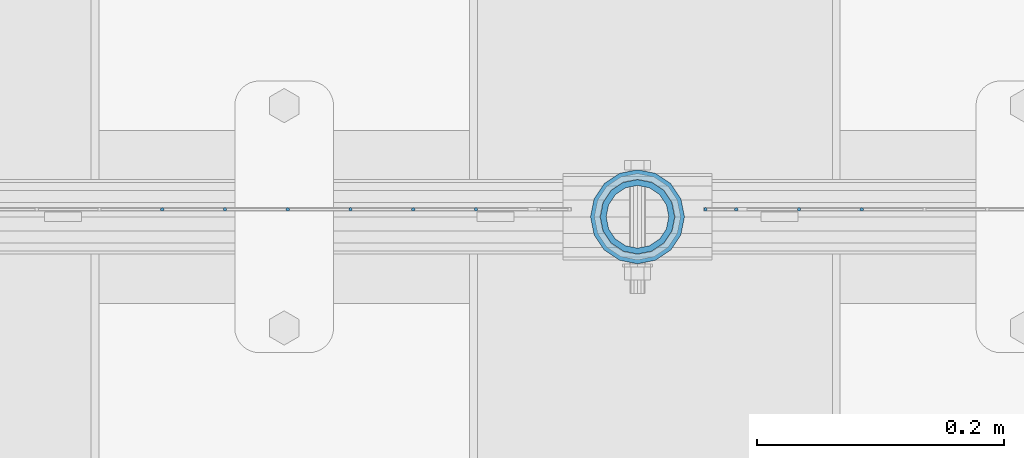
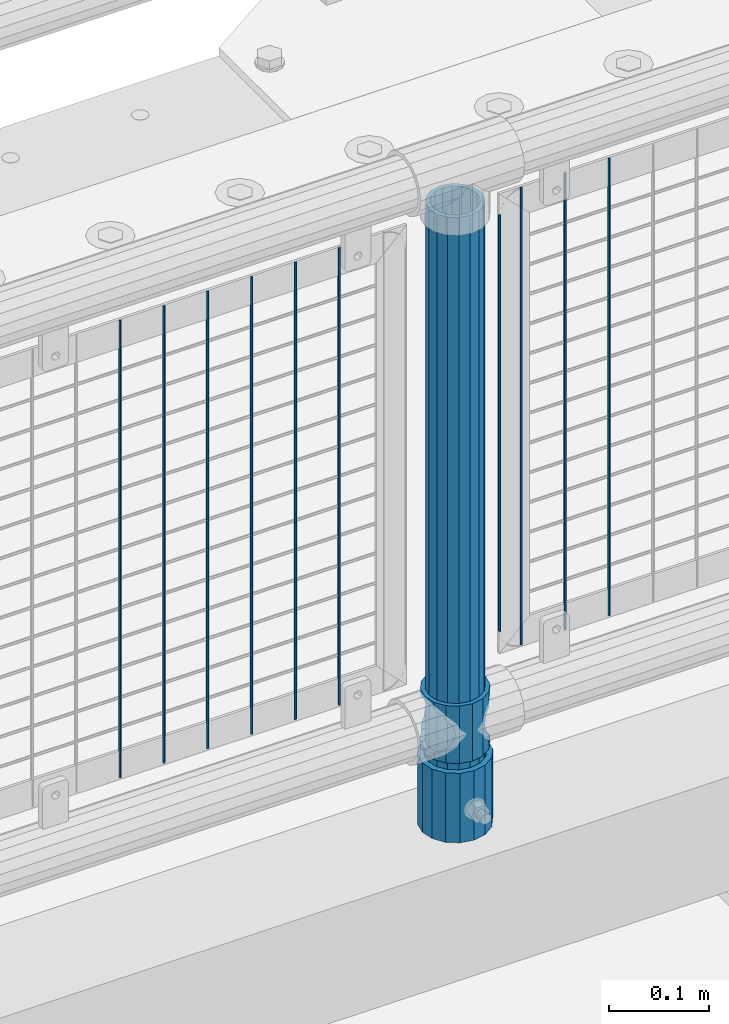
# One storey, part 84 of 270: 13 columns.
"""IFC2X3 building model written with IfcOpenShell, lengths in millimetres."""

from ifc_helpers import new_model, si_unit, frame, origin_with_axes, place, context, subcontext, project, spatial, faceted_brep, material, type_object, element, save


model = new_model("IFC2X3")

# Units and contexts
model_context = context("Model", 3, precision=1e-05, world=origin_with_axes())
body_context = subcontext(model_context, "Body", "Model", "MODEL_VIEW")
ifc_project = project(units=[si_unit("LENGTHUNIT", "METRE", prefix="MILLI"), si_unit("AREAUNIT", "SQUARE_METRE"), si_unit("VOLUMEUNIT", "CUBIC_METRE"), si_unit("MASSUNIT", "GRAM", prefix="KILO"), si_unit("TIMEUNIT", "SECOND"), si_unit("PLANEANGLEUNIT", "RADIAN"), si_unit("SOLIDANGLEUNIT", "STERADIAN"), si_unit("THERMODYNAMICTEMPERATUREUNIT", "DEGREE_CELSIUS"), si_unit("LUMINOUSINTENSITYUNIT", "LUMEN")], contexts=[model_context])

# Site, building, storey
site_placement = place(None, origin_with_axes())
site = spatial("IfcSite", under=ifc_project, at=site_placement, CompositionType="ELEMENT")
building_placement = place(site_placement, origin_with_axes())
building = spatial("IfcBuilding", under=site, at=building_placement, Name="Standard", CompositionType="ELEMENT")
storey_placement = place(building_placement, origin_with_axes())
storey = spatial("IfcBuildingStorey", under=building, at=storey_placement, Name="Undefined", CompositionType="ELEMENT", Elevation=0.0)

# Columns
ifc_material_1 = material()
column_type_1 = type_object("IfcColumnType", PredefinedType="NOTDEFINED")
column_1_placement = place(storey_placement, frame((8786.0, -16335.5, 168.02), z_axis=(-1.0, 0.0, 0.0), x_axis=(0.0, 0.0, 1.0)))
element("IfcColumn", 1, at=column_1_placement, inside=storey, type_object=column_type_1, material=ifc_material_1, context=body_context, shape_type="Brep", body=[
    faceted_brep([(0.0, -25.3500000000004, 0.0), (0.0, -23.4203461491616, 9.70102501045403), (760.0, -23.4203461491616, 9.70102501045403), (760.0, -25.3500000000004, 0.0), (0.0, -17.9251569030785, 17.9251569030785), (760.0, -17.9251569030785, 17.9251569030785), (0.0, -9.70102501045585, 23.4203461491597), (760.0, -9.70102501045585, 23.4203461491597), (0.0, 0.0, 25.3499999999985), (760.0, 0.0, 25.3499999999985), (0.0, 9.70102501045585, 23.4203461491597), (760.0, 9.70102501045585, 23.4203461491597), (0.0, 17.9251569030785, 17.9251569030785), (760.0, 17.9251569030785, 17.9251569030785), (0.0, 23.4203461491616, 9.70102501045403), (760.0, 23.4203461491616, 9.70102501045403), (0.0, 25.3500000000004, 0.0), (760.0, 25.3500000000004, 0.0), (0.0, 23.4203461491616, -9.70102501045403), (760.0, 23.4203461491616, -9.70102501045403), (0.0, 17.9251569030785, -17.9251569030785), (760.0, 17.9251569030785, -17.9251569030785), (0.0, 9.70102501045585, -23.4203461491597), (760.0, 9.70102501045585, -23.4203461491597), (0.0, 0.0, -25.3499999999985), (760.0, 0.0, -25.3499999999985), (0.0, -9.70102501045585, -23.4203461491597), (760.0, -9.70102501045585, -23.4203461491597), (0.0, -17.9251569030785, -17.9251569030785), (760.0, -17.9251569030785, -17.9251569030785), (0.0, -23.4203461491616, -9.70102501045403), (760.0, -23.4203461491616, -9.70102501045403), (0.0, -30.1499999999996, 0.0), (0.0, -27.8549679052157, -11.5379054858058), (760.0, -27.8549679052157, -11.5379054858058), (760.0, -30.1499999999996, 0.0), (0.0, -21.3192694527752, -21.3192694527752), (760.0, -21.3192694527752, -21.3192694527752), (0.0, -11.5379054858076, -27.8549679052157), (760.0, -11.5379054858076, -27.8549679052157), (0.0, 0.0, -30.1500000000015), (760.0, 0.0, -30.1500000000015), (0.0, 11.5379054858076, -27.8549679052157), (760.0, 11.5379054858076, -27.8549679052157), (0.0, 21.3192694527752, -21.3192694527752), (760.0, 21.3192694527752, -21.3192694527752), (0.0, 27.8549679052157, -11.5379054858058), (760.0, 27.8549679052157, -11.5379054858058), (0.0, 30.1499999999996, 0.0), (760.0, 30.1499999999996, 0.0), (0.0, 27.8549679052157, 11.5379054858058), (760.0, 27.8549679052157, 11.5379054858058), (0.0, 21.3192694527752, 21.3192694527752), (760.0, 21.3192694527752, 21.3192694527752), (0.0, 11.5379054858076, 27.8549679052157), (760.0, 11.5379054858076, 27.8549679052157), (0.0, 0.0, 30.1500000000015), (760.0, 0.0, 30.1500000000015), (0.0, -11.5379054858076, 27.8549679052157), (760.0, -11.5379054858076, 27.8549679052157), (0.0, -21.3192694527752, 21.3192694527752), (760.0, -21.3192694527752, 21.3192694527752), (0.0, -27.8549679052157, 11.5379054858058), (760.0, -27.8549679052157, 11.5379054858058)], [[[0, 1, 2, 3]], [[1, 4, 5, 2]], [[4, 6, 7, 5]], [[6, 8, 9, 7]], [[8, 10, 11, 9]], [[10, 12, 13, 11]], [[12, 14, 15, 13]], [[14, 16, 17, 15]], [[16, 18, 19, 17]], [[18, 20, 21, 19]], [[20, 22, 23, 21]], [[22, 24, 25, 23]], [[24, 26, 27, 25]], [[26, 28, 29, 27]], [[28, 30, 31, 29]], [[30, 0, 3, 31]], [[32, 33, 34, 35]], [[33, 36, 37, 34]], [[36, 38, 39, 37]], [[38, 40, 41, 39]], [[40, 42, 43, 41]], [[42, 44, 45, 43]], [[44, 46, 47, 45]], [[46, 48, 49, 47]], [[48, 50, 51, 49]], [[50, 52, 53, 51]], [[52, 54, 55, 53]], [[54, 56, 57, 55]], [[56, 58, 59, 57]], [[58, 60, 61, 59]], [[60, 62, 63, 61]], [[62, 32, 35, 63]], [[37, 39, 41, 43, 45, 47, 49, 51, 53, 55, 57, 59, 61, 63, 35, 34], [5, 7, 9, 11, 13, 15, 17, 19, 21, 23, 25, 27, 29, 31, 3, 2]], [[62, 60, 58, 56, 54, 52, 50, 48, 46, 44, 42, 40, 38, 36, 33, 32], [30, 28, 26, 24, 22, 20, 18, 16, 14, 12, 10, 8, 6, 4, 1, 0]]]),
])
column_type_2 = type_object("IfcColumnType", PredefinedType="NOTDEFINED")
column_2_placement = place(storey_placement, frame((8786.0, -16335.5, 168.02), z_axis=(0.0, 1.0, 0.0), x_axis=(0.0, 0.0, 1.0)))
element("IfcColumn", 2, at=column_2_placement, inside=storey, type_object=column_type_2, material=ifc_material_1, context=body_context, shape_type="Brep", body=[
    faceted_brep([(0.0, -31.75, 0.0), (0.0, -29.3331751572332, 12.1501989775916), (85.0, -29.3331751572332, 12.1501989775916), (85.0, -31.75, 0.0), (0.0, -22.4506403026717, 22.4506403026735), (85.0, -22.4506403026717, 22.4506403026735), (0.0, -12.1501989775934, 29.3331751572332), (85.0, -12.1501989775934, 29.3331751572332), (0.0, 0.0, 31.75), (85.0, 0.0, 31.75), (0.0, 12.1501989775934, 29.3331751572332), (85.0, 12.1501989775934, 29.3331751572332), (0.0, 22.4506403026717, 22.4506403026735), (85.0, 22.4506403026717, 22.4506403026735), (0.0, 29.3331751572332, 12.1501989775916), (85.0, 29.3331751572332, 12.1501989775916), (0.0, 31.75, 0.0), (85.0, 31.75, 0.0), (0.0, 29.3331751572332, -12.1501989775916), (85.0, 29.3331751572332, -12.1501989775916), (0.0, 22.4506403026717, -22.4506403026735), (85.0, 22.4506403026717, -22.4506403026735), (0.0, 12.1501989775934, -29.3331751572332), (85.0, 12.1501989775934, -29.3331751572332), (0.0, 0.0, -31.75), (85.0, 0.0, -31.75), (0.0, -12.1501989775934, -29.3331751572332), (85.0, -12.1501989775934, -29.3331751572332), (0.0, -22.4506403026717, -22.4506403026735), (85.0, -22.4506403026717, -22.4506403026735), (0.0, -29.3331751572332, -12.1501989775916), (85.0, -29.3331751572332, -12.1501989775916), (0.0, -38.0499999999993, 0.0), (0.0, -35.1536162120537, -14.561104601491), (85.0, -35.1536162120537, -14.561104601491), (85.0, -38.0499999999993, 0.0), (0.0, -26.9054130241493, -26.9054130241475), (85.0, -26.9054130241493, -26.9054130241475), (0.0, -14.5611046014928, -35.1536162120537), (85.0, -14.5611046014928, -35.1536162120537), (0.0, 0.0, -38.0499999999993), (85.0, 0.0, -38.0499999999993), (0.0, 14.5611046014928, -35.1536162120537), (85.0, 14.5611046014928, -35.1536162120537), (0.0, 26.9054130241493, -26.9054130241475), (85.0, 26.9054130241493, -26.9054130241475), (0.0, 35.1536162120537, -14.561104601491), (85.0, 35.1536162120537, -14.561104601491), (0.0, 38.0499999999993, 0.0), (85.0, 38.0499999999993, 0.0), (0.0, 35.1536162120537, 14.561104601491), (85.0, 35.1536162120537, 14.561104601491), (0.0, 26.9054130241493, 26.9054130241475), (85.0, 26.9054130241493, 26.9054130241475), (0.0, 14.5611046014928, 35.1536162120537), (85.0, 14.5611046014928, 35.1536162120537), (0.0, 0.0, 38.0499999999993), (85.0, 0.0, 38.0499999999993), (0.0, -14.5611046014928, 35.1536162120537), (85.0, -14.5611046014928, 35.1536162120537), (0.0, -26.9054130241493, 26.9054130241475), (85.0, -26.9054130241493, 26.9054130241475), (0.0, -35.1536162120537, 14.561104601491), (85.0, -35.1536162120537, 14.561104601491)], [[[0, 1, 2, 3]], [[1, 4, 5, 2]], [[4, 6, 7, 5]], [[6, 8, 9, 7]], [[8, 10, 11, 9]], [[10, 12, 13, 11]], [[12, 14, 15, 13]], [[14, 16, 17, 15]], [[16, 18, 19, 17]], [[18, 20, 21, 19]], [[20, 22, 23, 21]], [[22, 24, 25, 23]], [[24, 26, 27, 25]], [[26, 28, 29, 27]], [[28, 30, 31, 29]], [[30, 0, 3, 31]], [[32, 33, 34, 35]], [[33, 36, 37, 34]], [[36, 38, 39, 37]], [[38, 40, 41, 39]], [[40, 42, 43, 41]], [[42, 44, 45, 43]], [[44, 46, 47, 45]], [[46, 48, 49, 47]], [[48, 50, 51, 49]], [[50, 52, 53, 51]], [[52, 54, 55, 53]], [[54, 56, 57, 55]], [[56, 58, 59, 57]], [[58, 60, 61, 59]], [[60, 62, 63, 61]], [[62, 32, 35, 63]], [[37, 39, 41, 43, 45, 47, 49, 51, 53, 55, 57, 59, 61, 63, 35, 34], [5, 7, 9, 11, 13, 15, 17, 19, 21, 23, 25, 27, 29, 31, 3, 2]], [[62, 60, 58, 56, 54, 52, 50, 48, 46, 44, 42, 40, 38, 36, 33, 32], [30, 28, 26, 24, 22, 20, 18, 16, 14, 12, 10, 8, 6, 4, 1, 0]]]),
])
ifc_material_2 = material(Name="Misc_Undefined")
column_type_3 = type_object("IfcColumnType", PredefinedType="NOTDEFINED")
column_3_placement = place(storey_placement, frame((8786.0, -16335.5, 263.02), z_axis=(-1.0, 0.0, 0.0), x_axis=(0.0, 0.0, 1.0)))
element("IfcColumn", 3, at=column_3_placement, inside=storey, type_object=column_type_3, material=ifc_material_2, context=body_context, shape_type="Brep", body=[
    faceted_brep([(63.1897438117183, 11.6144421722802, -32.8397438117208), (63.1897438117183, 11.6144421722802, -28.0397438117179), (56.6106908090125, 21.4606908090118, -21.46069080901), (56.6106908090125, 21.4606908090118, -27.1226768591005), (61.9623795176767, 13.4513226476338, -32.4743655677703), (46.7644421722812, 28.0397438117179, -11.614442172282), (46.7644421722812, 28.0397438117179, -20.0882031229812), (51.5310424080071, 24.8548033587067, -24.8548033587067), (35.1500000000015, 30.35, 0.0), (35.1500000000008, 30.3500000000004, -16.6306603983612), (23.5355578277203, 28.0397438117179, -11.614442172282), (23.5355578277203, 28.0397438117179, -20.0882031229812), (18.7689575919954, 24.8548033587067, -24.8548033587067), (13.689309190989, 21.4606908090118, -21.46069080901), (13.689309190989, 21.4606908090118, -27.1226768591005), (8.33762048232484, 13.4513226476338, -32.4743655677703), (7.11025618828324, 11.6144421722802, -28.0397438117179), (7.11025618828324, 11.6144421722802, -32.8397438117208), (4.80000000000075, 0.0, -30.3499999999985), (4.80000000000075, 0.0, -35.1500000000015), (7.11025618828319, -11.6144421722802, -28.0397438117179), (7.11025618828319, -11.6144421722802, -32.8397438117172), (13.689309190989, -21.4606908090118, -21.46069080901), (13.689309190989, -21.4606908090118, -27.1226768591041), (8.33762048232484, -13.4513226476338, -32.4743655677703), (23.5355578277203, -28.0397438117179, -11.614442172282), (23.5355578277203, -28.0397438117179, -20.0882031229885), (18.7689575919954, -24.8548033587067, -24.8548033587067), (35.1500000000015, -30.35, 0.0), (35.1500000000008, -30.3500000000004, -16.6306603983721), (46.7644421722812, -28.0397438117179, -11.614442172282), (46.7644421722812, -28.0397438117179, -20.0882031229885), (51.5310424080071, -24.8548033587067, -24.8548033587067), (56.6106908090125, -21.4606908090118, -21.46069080901), (56.6106908090125, -21.4606908090118, -27.1226768591041), (61.9623795176767, -13.4513226476338, -32.4743655677703), (63.1897438117183, -11.6144421722802, -28.0397438117179), (63.1897438117183, -11.6144421722802, -32.8397438117172), (65.5000000000008, 0.0, -30.3499999999985), (65.5000000000008, 0.0, -35.1500000000015), (0.0, -28.0397438117179, -11.614442172282), (0.0, -30.3500000000004, 0.0), (0.0, -21.4606908090118, -21.46069080901), (0.0, -11.6144421722802, -28.0397438117179), (0.0, 0.0, -30.3499999999985), (0.0, 11.6144421722802, -28.0397438117179), (0.0, 21.4606908090118, -21.46069080901), (0.0, 28.0397438117179, -11.614442172282), (0.0, 30.3500000000004, 0.0), (0.0, 28.0397438117179, 11.614442172282), (23.5355578277192, 28.0397438117179, 11.614442172282), (0.0, 21.4606908090118, 21.46069080901), (13.6893091909879, 21.4606908090118, 21.46069080901), (0.0, 11.6144421722802, 28.0397438117179), (7.11025618828211, 11.6144421722802, 28.0397438117179), (0.0, 0.0, 30.3499999999985), (4.79999999999961, 0.0, 30.3499999999985), (0.0, -11.6144421722802, 28.0397438117179), (7.11025618828205, -11.6144421722802, 28.0397438117179), (0.0, -21.4606908090118, 21.46069080901), (13.6893091909879, -21.4606908090118, 21.46069080901), (0.0, -28.0397438117179, 11.614442172282), (23.5355578277191, -28.0397438117179, 11.614442172282), (0.0, -32.4743655677721, 13.4513226476338), (0.0, -35.1499999999996, 0.0), (70.2999999999993, -35.1499999999996, 0.0), (70.2999999999993, -32.4743655677721, 13.4513226476338), (0.0, 13.4513226476338, -32.4743655677703), (0.0, 24.8548033587067, -24.8548033587067), (0.0, 0.0, -35.1499999999996), (0.0, -13.4513226476338, -32.4743655677703), (0.0, -24.8548033587067, -24.8548033587067), (0.0, -24.8548033587067, 24.8548033587067), (0.0, -13.4513226476338, 32.4743655677703), (0.0, 0.0, 35.1499999999996), (0.0, 13.4513226476338, 32.4743655677703), (0.0, 24.8548033587067, 24.8548033587067), (0.0, 32.4743655677721, 13.4513226476338), (0.0, 35.1499999999996, 0.0), (0.0, 32.4743655677721, -13.4513226476338), (0.0, -32.4743655677721, -13.4513226476338), (70.2999999999993, 32.4743655677721, 13.4513226476338), (70.2999999999993, 35.1499999999996, 0.0), (70.2999999999993, 32.4743655677721, -13.4513226476338), (70.2999999999993, 24.8548033587067, -24.8548033587067), (70.2999999999993, 13.4513226476338, -32.4743655677703), (70.2999999999993, 0.0, -35.1500000000015), (70.2999999999993, -13.4513226476338, -32.4743655677703), (70.2999999999993, -24.8548033587067, -24.8548033587067), (70.2999999999993, -32.4743655677721, -13.4513226476338), (70.2999999999993, 28.0397438117179, 11.614442172282), (70.2999999999993, 21.4606908090118, 21.46069080901), (56.6106908090114, 21.4606908090118, 21.46069080901), (46.7644421722801, 28.0397438117179, 11.614442172282), (70.2999999999993, 11.6144421722802, 28.0397438117179), (63.1897438117172, 11.6144421722802, 28.0397438117179), (70.2999999999993, 0.0, 30.3499999999985), (65.4999999999997, 0.0, 30.3499999999985), (70.2999999999993, -11.6144421722802, 28.0397438117179), (63.1897438117172, -11.6144421722802, 28.0397438117179), (70.2999999999993, -21.4606908090118, 21.46069080901), (56.6106908090114, -21.4606908090118, 21.46069080901), (70.2999999999993, -28.0397438117179, 11.614442172282), (46.7644421722801, -28.0397438117179, 11.614442172282), (70.2999999999993, -11.6144421722802, -28.0397438117179), (70.2999999999993, 0.0, -30.3499999999985), (70.2999999999993, -21.4606908090118, -21.46069080901), (70.2999999999993, -28.0397438117179, -11.614442172282), (70.2999999999993, -30.3500000000004, 0.0), (70.2999999999993, 24.8548033587067, 24.8548033587067), (70.2999999999993, 13.4513226476338, 32.4743655677703), (70.2999999999993, 0.0, 35.1500000000015), (70.2999999999993, -13.4513226476338, 32.4743655677703), (70.2999999999993, -24.8548033587067, 24.8548033587067), (70.2999999999993, 30.3500000000004, 0.0), (70.2999999999993, 28.0397438117179, -11.614442172282), (70.2999999999993, 21.4606908090118, -21.46069080901), (70.2999999999993, 11.6144421722802, -28.0397438117179), (61.9623795176767, 13.4513226476338, 32.4743655677703), (51.5310424080039, 24.8548033587067, 24.8548033587067), (56.6106908090114, 21.4606908090118, 27.1226768591041), (65.4999999999997, 0.0, 35.1500000000015), (63.1897438117172, 11.6144421722802, 32.8397438117172), (63.1897438117172, -11.6144421722802, 32.8397438117172), (61.9623795176767, -13.4513226476338, 32.4743655677703), (56.6106908090114, -21.4606908090118, 27.1226768591077), (51.5310424080071, -24.8548033587067, 24.8548033587067), (18.7689575919954, -24.8548033587067, 24.8548033587067), (46.7644421722801, -28.0397438117179, 20.0882031229849), (35.1499999999996, -30.3500000000004, 16.6306603983649), (23.5355578277191, -28.0397438117179, 20.0882031229849), (8.33762048232262, -13.4513226476338, 32.4743655677703), (13.6893091909879, -21.4606908090118, 27.1226768591077), (4.79999999999961, 0.0, 35.1500000000015), (7.11025618828205, -11.6144421722802, 32.8397438117172), (7.11025618828211, 11.6144421722802, 32.8397438117172), (8.33762048232262, 13.4513226476338, 32.4743655677703), (13.6893091909879, 21.4606908090118, 27.1226768591041), (18.7689575919954, 24.8548033587067, 24.8548033587067), (23.5355578277192, 28.0397438117179, 20.0882031229885), (35.1499999999996, 30.3500000000004, 16.6306603983685), (46.7644421722801, 28.0397438117179, 20.0882031229885)], [[[0, 1, 2, 3, 4]], [[3, 2, 5, 6, 7]], [[6, 5, 8, 9]], [[9, 8, 10, 11]], [[12, 11, 10, 13, 14]], [[15, 14, 13, 16, 17]], [[17, 16, 18, 19]], [[19, 18, 20, 21]], [[21, 20, 22, 23, 24]], [[23, 22, 25, 26, 27]], [[26, 25, 28, 29]], [[29, 28, 30, 31]], [[32, 31, 30, 33, 34]], [[35, 34, 33, 36, 37]], [[37, 36, 38, 39]], [[39, 38, 1, 0]], [[40, 41, 28, 25]], [[42, 40, 25, 22]], [[43, 42, 22, 20]], [[44, 43, 20, 18]], [[45, 44, 18, 16]], [[46, 45, 16, 13]], [[47, 46, 13, 10]], [[48, 47, 10, 8]], [[49, 48, 8, 50]], [[51, 49, 50, 52]], [[53, 51, 52, 54]], [[55, 53, 54, 56]], [[57, 55, 56, 58]], [[59, 57, 58, 60]], [[61, 59, 60, 62]], [[41, 61, 62, 28]], [[63, 64, 65, 66]], [[67, 68, 12, 14, 15]], [[69, 67, 15, 17, 19]], [[24, 70, 69, 19, 21]], [[27, 71, 70, 24, 23]], [[63, 72, 73, 74, 75, 76, 77, 78, 79, 68, 67, 69, 70, 71, 80, 64], [40, 42, 43, 44, 45, 46, 47, 48, 49, 51, 53, 55, 57, 59, 61, 41]], [[78, 77, 81, 82]], [[79, 78, 82, 83]], [[68, 79, 83, 84, 7, 6, 9, 11, 12]], [[7, 84, 85, 4, 3]], [[4, 85, 86, 39, 0]], [[87, 88, 32, 34, 35]], [[86, 87, 35, 37, 39]], [[29, 31, 32, 88, 89, 80, 71, 27, 26]], [[64, 80, 89, 65]], [[90, 91, 92, 93]], [[91, 94, 95, 92]], [[94, 96, 97, 95]], [[96, 98, 99, 97]], [[98, 100, 101, 99]], [[100, 102, 103, 101]], [[104, 105, 38, 36]], [[106, 104, 36, 33]], [[107, 106, 33, 30]], [[108, 107, 30, 28]], [[102, 108, 28, 103]], [[88, 87, 86, 85, 84, 83, 82, 81, 109, 110, 111, 112, 113, 66, 65, 89], [100, 98, 96, 94, 91, 90, 114, 115, 116, 117, 105, 104, 106, 107, 108, 102]], [[118, 110, 109, 119, 120]], [[121, 111, 110, 118, 122]], [[112, 111, 121, 123, 124]], [[113, 112, 124, 125, 126]], [[127, 72, 63, 66, 113, 126, 128, 129, 130]], [[131, 73, 72, 127, 132]], [[133, 74, 73, 131, 134]], [[75, 74, 133, 135, 136]], [[76, 75, 136, 137, 138]], [[119, 109, 81, 77, 76, 138, 139, 140, 141]], [[92, 120, 119, 141, 93]], [[95, 122, 118, 120, 92]], [[97, 121, 122, 95]], [[99, 123, 121, 97]], [[101, 125, 124, 123, 99]], [[103, 128, 126, 125, 101]], [[28, 129, 128, 103]], [[62, 130, 129, 28]], [[60, 132, 127, 130, 62]], [[58, 134, 131, 132, 60]], [[56, 133, 134, 58]], [[54, 135, 133, 56]], [[52, 137, 136, 135, 54]], [[50, 139, 138, 137, 52]], [[8, 140, 139, 50]], [[93, 141, 140, 8]], [[114, 90, 93, 8]], [[115, 114, 8, 5]], [[116, 115, 5, 2]], [[117, 116, 2, 1]], [[105, 117, 1, 38]]]),
])
column_type_4 = type_object("IfcColumnType", Name="D3", PredefinedType="NOTDEFINED")
for number, where, z_axis, x_axis in (
    (4, (8967.586, -16329.5, 353.02), (-1.0, 0.0, 0.0), (0.0, 0.0, 1.0)),
    (5, (8916.793, -16329.5, 353.02), (-1.0, 0.0, 0.0), (0.0, 0.0, 1.0)),
):
    element("IfcColumn", number, at=place(storey_placement, frame(where, z_axis=z_axis, x_axis=x_axis)), inside=storey, type_object=column_type_4, material=ifc_material_2, ObjectType="D3", context=body_context, shape_type="Brep", body=[
        faceted_brep([(0.0, -1.5, 0.0), (0.0, -0.75, -1.29903810567669), (560.0, -0.75, -1.29903810567703), (560.0, -1.5, 0.0), (0.0, 0.75, -1.29903810567669), (560.0, 0.75, -1.29903810567703), (0.0, 1.5, 0.0), (560.0, 1.5, 0.0), (0.0, 0.75, 1.29903810567669), (560.0, 0.75, 1.29903810567703), (0.0, -0.75, 1.29903810567669), (560.0, -0.75, 1.29903810567703)], [[[0, 1, 2, 3]], [[1, 4, 5, 2]], [[4, 6, 7, 5]], [[6, 8, 9, 7]], [[8, 10, 11, 9]], [[10, 0, 3, 11]], [[5, 7, 9, 11, 3, 2]], [[10, 8, 6, 4, 1, 0]]]),
    ])
column_4_placement = place(storey_placement, frame((8841.0, -16329.5, 378.02), z_axis=(-1.0, 0.0, 0.0), x_axis=(0.0, 0.0, 1.0)))
element("IfcColumn", 6, at=column_4_placement, inside=storey, type_object=column_type_4, material=ifc_material_2, ObjectType="D3", context=body_context, shape_type="Brep", body=[
    faceted_brep([(0.0, -1.5, 0.0), (0.0, -0.75, -1.29903810567669), (510.0, -0.75, -1.29903810567703), (510.0, -1.5, 0.0), (0.0, 0.75, -1.29903810567669), (510.0, 0.75, -1.29903810567703), (0.0, 1.5, 0.0), (510.0, 1.5, 0.0), (0.0, 0.75, 1.29903810567669), (510.0, 0.75, 1.29903810567703), (0.0, -0.75, 1.29903810567669), (510.0, -0.75, 1.29903810567703)], [[[0, 1, 2, 3]], [[1, 4, 5, 2]], [[4, 6, 7, 5]], [[6, 8, 9, 7]], [[8, 10, 11, 9]], [[10, 0, 3, 11]], [[5, 7, 9, 11, 3, 2]], [[10, 8, 6, 4, 1, 0]]]),
])
for number, where, z_axis, x_axis in (
    (7, (8866.0, -16329.5, 353.02), (-1.0, 0.0, 0.0), (0.0, 0.0, 1.0)),
    (8, (8655.204, -16329.5, 353.02), (-1.0, 0.0, 0.0), (0.0, 0.0, 1.0)),
    (9, (8604.411, -16329.5, 353.02), (-1.0, 0.0, 0.0), (0.0, 0.0, 1.0)),
    (10, (8553.618, -16329.5, 353.02), (-1.0, 0.0, 0.0), (0.0, 0.0, 1.0)),
    (11, (8502.825, -16329.5, 353.02), (-1.0, 0.0, 0.0), (0.0, 0.0, 1.0)),
    (12, (8452.032, -16329.5, 353.02), (-1.0, 0.0, 0.0), (0.0, 0.0, 1.0)),
    (13, (8401.239, -16329.5, 353.02), (-1.0, 0.0, 0.0), (0.0, 0.0, 1.0)),
):
    element("IfcColumn", number, at=place(storey_placement, frame(where, z_axis=z_axis, x_axis=x_axis)), inside=storey, type_object=column_type_4, material=ifc_material_2, ObjectType="D3", context=body_context, shape_type="Brep", body=[
        faceted_brep([(0.0, -1.5, 0.0), (0.0, -0.75, -1.29903810567669), (560.0, -0.75, -1.29903810567703), (560.0, -1.5, 0.0), (0.0, 0.75, -1.29903810567669), (560.0, 0.75, -1.29903810567703), (0.0, 1.5, 0.0), (560.0, 1.5, 0.0), (0.0, 0.75, 1.29903810567669), (560.0, 0.75, 1.29903810567703), (0.0, -0.75, 1.29903810567669), (560.0, -0.75, 1.29903810567703)], [[[0, 1, 2, 3]], [[1, 4, 5, 2]], [[4, 6, 7, 5]], [[6, 8, 9, 7]], [[8, 10, 11, 9]], [[10, 0, 3, 11]], [[5, 7, 9, 11, 3, 2]], [[10, 8, 6, 4, 1, 0]]]),
    ])

save(model, "model.ifc")
